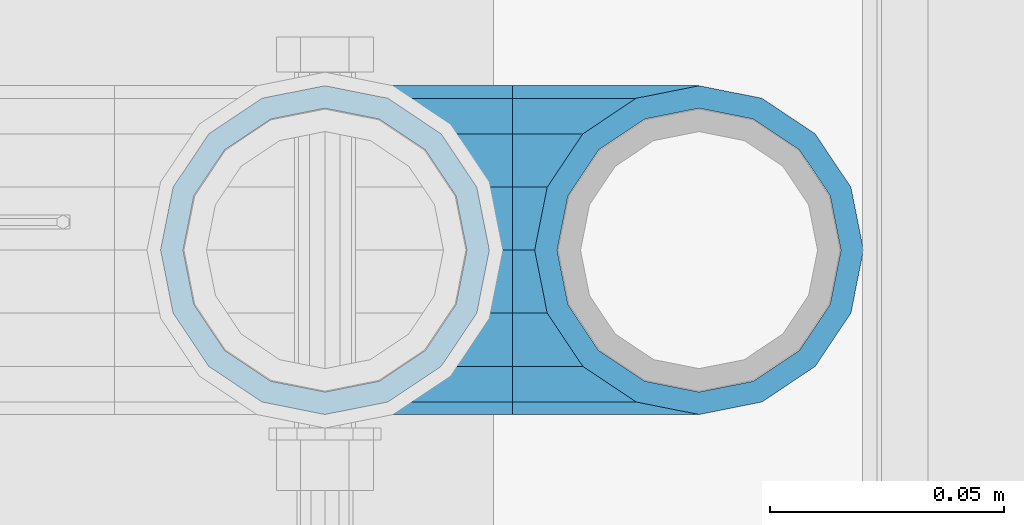
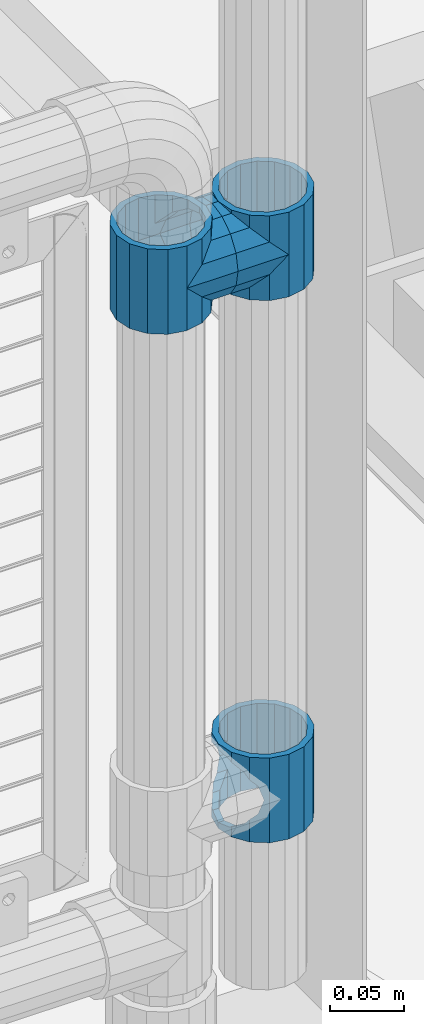
# One storey, part 172 of 247: 5 beams.
"""IFC2X3 building model written with IfcOpenShell, lengths in millimetres."""

import ifcopenshell
import ifcopenshell.guid

model = None  # the IFC model being written
_history = None  # IfcOwnerHistory: only IFC2X3 demands one
_inside = {}  # id of a spatial element -> (the spatial element, [elements in it])
_under = {}  # id of a project, library or spatial element -> (it, [spatial elements below it])
_declared = {}  # id of a project -> (the project, [libraries it declares])
_typed = {}  # id of a type object -> (the type object, [elements of that type])
_made_of = {}  # id of a material, layer set ... -> (it, [elements and type objects made of it])


def new_model(schema):
    """Start an empty IFC model of exactly this schema.

    Asked for "IFC4X3", IfcOpenShell would pick the latest addendum, in which some entities
    have other attributes; the version numbers below select the first issue.
    IFC2X3 requires an IfcOwnerHistory on every rooted entity: one is made here for all.
    """
    global model, _history
    if schema == "IFC4X3":
        model = ifcopenshell.file(schema_version=(4, 3, 0, 0))
    else:
        model = ifcopenshell.file(schema=schema)
    _inside.clear()
    _under.clear()
    _declared.clear()
    _typed.clear()
    _made_of.clear()
    _history = None
    if model.schema == "IFC2X3":
        org = make("IfcOrganization", Name="unknown")
        user = make(
            "IfcPersonAndOrganization",
            ThePerson=make("IfcPerson", FamilyName="unknown"),
            TheOrganization=org,
        )
        app = make(
            "IfcApplication",
            ApplicationDeveloper=org,
            Version="unknown",
            ApplicationFullName="unknown",
            ApplicationIdentifier="unknown",
        )
        _history = make(
            "IfcOwnerHistory",
            OwningUser=user,
            OwningApplication=app,
            ChangeAction="ADDED",
            CreationDate=0,
        )
    return model


def make(cls, **values):
    """One entity of the class cls with the attributes given. An attribute that is None is left unset."""
    return model.create_entity(
        cls, **{name: value for name, value in values.items() if value is not None}
    )


def rooted(cls, **values):
    """An entity with a GlobalId (a new one), such as an element, a storey or a relation."""
    return make(cls, GlobalId=ifcopenshell.guid.new(), OwnerHistory=_history, **values)


def si_unit(unit_type, name, prefix=None):
    """IfcSIUnit, for example si_unit("LENGTHUNIT", "METRE", prefix="MILLI")."""
    return make("IfcSIUnit", UnitType=unit_type, Prefix=prefix, Name=name)


def assignment(units):
    """IfcUnitAssignment: the units of a project."""
    return None if units is None else make("IfcUnitAssignment", Units=units)


def point(xyz):
    """IfcCartesianPoint."""
    return None if xyz is None else make("IfcCartesianPoint", Coordinates=xyz)


def direction(xyz):
    """IfcDirection."""
    return None if xyz is None else make("IfcDirection", DirectionRatios=xyz)


def frame(location, z_axis=None, x_axis=None):
    """IfcAxis2Placement3D, a coordinate frame: its origin and axes. An axis left out is left unset."""
    return make(
        "IfcAxis2Placement3D",
        Location=point(location),
        Axis=direction(z_axis),
        RefDirection=direction(x_axis),
    )


def origin_with_axes():
    """The frame at (0, 0, 0) with the z axis (0, 0, 1) and the x axis (1, 0, 0) written out."""
    return frame((0.0, 0.0, 0.0), z_axis=(0.0, 0.0, 1.0), x_axis=(1.0, 0.0, 0.0))


def place(relative_to, where):
    """IfcLocalPlacement: puts the frame where relative to a parent placement (None: the world)."""
    return make(
        "IfcLocalPlacement", PlacementRelTo=relative_to, RelativePlacement=where
    )


def context(
    kind, dimensions, precision=None, world=None, true_north=None, identifier=None
):
    """IfcGeometricRepresentationContext, for example the 3D "Model" context."""
    return make(
        "IfcGeometricRepresentationContext",
        ContextIdentifier=identifier,
        ContextType=kind,
        CoordinateSpaceDimension=dimensions,
        Precision=precision,
        WorldCoordinateSystem=world,
        TrueNorth=true_north,
    )


def subcontext(parent, identifier, kind, view, scale=None):
    """IfcGeometricRepresentationSubContext, for example "Body" below "Model"."""
    return make(
        "IfcGeometricRepresentationSubContext",
        ContextIdentifier=identifier,
        ContextType=kind,
        ParentContext=parent,
        TargetScale=scale,
        TargetView=view,
    )


def project(units=None, contexts=None):
    """IfcProject with its units and contexts."""
    return rooted(
        "IfcProject",
        Name="project",
        RepresentationContexts=contexts,
        UnitsInContext=assignment(units),
    )


def spatial(cls, under=None, at=None, **own):
    """A site, building, storey or space (cls), placed at a placement, below another one or the project."""
    s = rooted(cls, ObjectPlacement=at, **own)
    if under is not None:
        _under.setdefault(under.id(), (under, []))[1].append(s)
    return s


def faces_of(points, faces, orient=None, outer=None):
    """IfcFace entities. A face is a list of loops; a loop is a list of indices into points, from 0.

    orient and outer hold one flag for each loop. By default every Orientation is true, the
    first loop of a face is its IfcFaceOuterBound and the others are IfcFaceBound.
    """
    made = []
    for i, loops in enumerate(faces):
        bounds = []
        for j, loop in enumerate(loops):
            is_outer = j == 0 if outer is None else outer[i][j]
            bounds.append(
                make(
                    "IfcFaceOuterBound" if is_outer else "IfcFaceBound",
                    Bound=make("IfcPolyLoop", Polygon=[points[k] for k in loop]),
                    Orientation=True if orient is None else orient[i][j],
                )
            )
        made.append(make("IfcFace", Bounds=bounds))
    return made


def faceted_brep(points, faces, orient=None, outer=None, voids=None):
    """IfcFacetedBrep: a solid bounded by flat faces; with voids (closed shells), ...WithVoids."""
    shared = [point(p) for p in points]
    hull = make("IfcClosedShell", CfsFaces=faces_of(shared, faces, orient, outer))
    if voids is None:
        return make("IfcFacetedBrep", Outer=hull)
    return make(
        "IfcFacetedBrepWithVoids",
        Outer=hull,
        Voids=[
            make(cls, CfsFaces=faces_of(shared, fs, o, b)) for cls, fs, o, b in voids
        ],
    )


def shape(context_of_items, identifier, shape_type, items):
    """IfcShapeRepresentation: the items that make up one representation, for example the "Body"."""
    return make(
        "IfcShapeRepresentation",
        ContextOfItems=context_of_items,
        RepresentationIdentifier=identifier,
        RepresentationType=shape_type,
        Items=items,
    )


def material(Name=None, Category=None):
    """IfcMaterial."""
    return make("IfcMaterial", Name=Name, Category=Category)


def made_of(thing, what):
    """Note that an element or type object is made of a material, layer set ...; save() writes the relation."""
    if what is not None:
        _made_of.setdefault(what.id(), (what, []))[1].append(thing)
    return thing


def type_object(cls, material=None, **own):
    """A type object (cls), such as IfcWallType, which elements share."""
    return made_of(rooted(cls, **own), material)


def element(
    cls,
    number,
    at=None,
    inside=None,
    cuts=None,
    type_object=None,
    material=None,
    context=None,
    identifier="Body",
    shape_type=None,
    held_by="IfcProductDefinitionShape",
    body=None,
    shapes=None,
    **own,
):
    """One element of the class cls, such as IfcWall. Its Tag is "e" and its number.

    at: its placement. inside: the storey or other place that contains it. cuts: it is an
    opening in that element (IfcRelVoidsElement). A single representation is given by context,
    identifier, shape_type and body (its items); several are given by shapes. held_by: the class
    of the entity that holds the representations. save() writes the other relations.
    """
    e = rooted(cls, Tag="e%d" % number, ObjectPlacement=at, **own)
    if body is not None:
        shapes = [shape(context, identifier, shape_type, body)]
    if shapes is not None:
        e.Representation = make(held_by, Representations=shapes)
    if inside is not None:
        _inside.setdefault(inside.id(), (inside, []))[1].append(e)
    if cuts is not None:
        rooted(
            "IfcRelVoidsElement", RelatingBuildingElement=cuts, RelatedOpeningElement=e
        )
    if type_object is not None:
        _typed.setdefault(type_object.id(), (type_object, []))[1].append(e)
    return made_of(e, material)


def aggregate(whole, parts):
    """IfcRelAggregates: a whole, such as a stair, and the parts it consists of."""
    return rooted("IfcRelAggregates", RelatingObject=whole, RelatedObjects=parts)


def save(model, path):
    """Write the relations noted so far, then the file.

    IfcRelAggregates (storeys below a building ...), IfcRelContainedInSpatialStructure (elements
    in a storey), IfcRelDefinesByType, IfcRelAssociatesMaterial and IfcRelDeclares: one each for
    every whole, place, type object, material and project.
    """
    for whole, parts in _under.values():
        aggregate(whole, parts)
    for where, things in _inside.values():
        rooted(
            "IfcRelContainedInSpatialStructure",
            RelatedElements=things,
            RelatingStructure=where,
        )
    for kind, things in _typed.values():
        rooted("IfcRelDefinesByType", RelatedObjects=things, RelatingType=kind)
    for what, things in _made_of.values():
        rooted("IfcRelAssociatesMaterial", RelatedObjects=things, RelatingMaterial=what)
    for by, libraries in _declared.values():
        rooted("IfcRelDeclares", RelatingContext=by, RelatedDefinitions=libraries)
    model.write(path)


model = new_model("IFC2X3")

# Units and contexts
model_context = context("Model", 3, precision=1e-05, world=origin_with_axes())
body_context = subcontext(model_context, "Body", "Model", "MODEL_VIEW")
ifc_project = project(units=[si_unit("LENGTHUNIT", "METRE", prefix="MILLI"), si_unit("AREAUNIT", "SQUARE_METRE"), si_unit("VOLUMEUNIT", "CUBIC_METRE"), si_unit("MASSUNIT", "GRAM", prefix="KILO"), si_unit("TIMEUNIT", "SECOND"), si_unit("PLANEANGLEUNIT", "RADIAN"), si_unit("SOLIDANGLEUNIT", "STERADIAN"), si_unit("THERMODYNAMICTEMPERATUREUNIT", "DEGREE_CELSIUS"), si_unit("LUMINOUSINTENSITYUNIT", "LUMEN")], contexts=[model_context])

# Site, building, storey
site_placement = place(None, origin_with_axes())
site = spatial("IfcSite", under=ifc_project, at=site_placement, CompositionType="ELEMENT")
building_placement = place(site_placement, origin_with_axes())
building = spatial("IfcBuilding", under=site, at=building_placement, Name="Standard", CompositionType="ELEMENT")
storey_placement = place(building_placement, origin_with_axes())
storey = spatial("IfcBuildingStorey", under=building, at=storey_placement, Name="Undefined", CompositionType="ELEMENT", Elevation=0.0)

# Beams
ifc_material = material(Name="Misc_Undefined")
beam_type = type_object("IfcBeamType", PredefinedType="NOTDEFINED")
beam_1_placement = place(storey_placement, frame((16301.0, 7664.5, 433.819999999999), z_axis=(1.0, 0.0, 0.0), x_axis=(0.0, 0.0, -1.0)))
element("IfcBeam", 1, at=beam_1_placement, inside=storey, type_object=beam_type, material=ifc_material, context=body_context, shape_type="Brep", body=[
    faceted_brep([(46.7644421722801, 28.0397438117179, -11.6144421722802), (46.7644421722801, 28.0397438117179, -20.088203122983), (51.5310424080055, 24.8548033587067, -24.8548033587067), (56.6106908090114, 21.4606908090118, -27.1226768591096), (56.6106908090114, 21.4606908090118, -21.4606908090118), (61.9623795176755, 13.4513226476329, -32.4743655677721), (63.1897438117172, 11.6144421722802, -32.839743811719), (63.1897438117172, 11.6144421722802, -28.0397438117179), (65.4999999999997, 0.0, -35.1499999999996), (65.4999999999997, 0.0, -30.3500000000004), (63.1897438117172, -11.6144421722802, -32.839743811719), (63.1897438117172, -11.6144421722802, -28.0397438117179), (61.9623795176754, -13.4513226476329, -32.4743655677721), (56.6106908090114, -21.4606908090118, -27.1226768591077), (56.6106908090114, -21.4606908090118, -21.4606908090118), (51.5310424080038, -24.8548033587067, -24.8548033587067), (46.7644421722801, -28.0397438117179, -20.0882031229885), (46.7644421722801, -28.0397438117179, -11.6144421722802), (35.1499999999996, -30.3500000000004, -16.6306603983739), (35.1499999999996, -30.35, 0.0), (23.5355578277191, -28.0397438117179, -20.0882031229885), (23.5355578277191, -28.0397438117179, -11.6144421722802), (18.768957591997, -24.8548033587067, -24.8548033587067), (13.6893091909879, -21.4606908090118, -27.1226768591077), (13.6893091909879, -21.4606908090118, -21.4606908090118), (8.33762048232325, -13.4513226476329, -32.4743655677721), (7.11025618828211, -11.6144421722802, -32.839743811719), (7.11025618828211, -11.6144421722802, -28.0397438117179), (4.79999999999961, 0.0, -35.1499999999996), (4.79999999999961, 0.0, -30.3500000000004), (7.11025618828211, 11.6144421722802, -32.839743811719), (7.11025618828211, 11.6144421722802, -28.0397438117179), (8.33762048232387, 13.4513226476329, -32.4743655677721), (13.6893091909879, 21.4606908090118, -27.1226768591096), (13.6893091909879, 21.4606908090118, -21.4606908090118), (18.768957591997, 24.8548033587067, -24.8548033587067), (23.5355578277192, 28.0397438117179, -20.088203122983), (23.5355578277192, 28.0397438117179, -11.6144421722802), (35.1499999999996, 30.3500000000004, -16.6306603983649), (35.1499999999996, 30.35, 0.0), (0.0, 32.4743655677721, -13.4513226476338), (0.0, 35.1499999999996, 0.0), (70.2999999999993, 35.1499999999996, 0.0), (70.2999999999993, 32.4743655677721, -13.4513226476338), (0.0, 32.4743655677721, 13.4513226476338), (70.2999999999993, 32.4743655677721, 13.4513226476338), (0.0, 24.8548033587067, 24.8548033587067), (70.2999999999993, 24.8548033587067, 24.8548033587067), (0.0, 13.4513226476329, 32.4743655677721), (70.2999999999993, 13.4513226476329, 32.4743655677721), (0.0, 0.0, 35.1499999999996), (70.2999999999993, 0.0, 35.1499999999996), (0.0, -13.4513226476329, 32.4743655677721), (70.2999999999993, -13.4513226476329, 32.4743655677721), (0.0, -24.8548033587067, 24.8548033587067), (70.2999999999993, -24.8548033587067, 24.8548033587067), (0.0, -32.4743655677721, 13.4513226476338), (70.2999999999993, -32.4743655677721, 13.4513226476338), (0.0, -35.1499999999996, 0.0), (70.2999999999993, -35.1499999999996, 0.0), (70.2999999999993, -30.3500000000004, 0.0), (70.2999999999993, -28.0397438117179, -11.6144421722802), (70.2999999999993, -21.4606908090118, -21.4606908090118), (70.2999999999993, -11.6144421722802, -28.0397438117179), (70.2999999999993, 0.0, -30.3500000000004), (70.2999999999993, 11.6144421722802, -28.0397438117179), (70.2999999999993, 21.4606908090118, -21.4606908090118), (70.2999999999993, 28.0397438117179, -11.6144421722802), (0.0, -28.0397438117179, -11.6144421722802), (0.0, -30.3500000000004, 0.0), (0.0, -21.4606908090118, -21.4606908090118), (0.0, -11.6144421722802, -28.0397438117179), (0.0, 0.0, -30.3500000000004), (0.0, 11.6144421722802, -28.0397438117179), (0.0, 21.4606908090118, -21.4606908090118), (0.0, 28.0397438117179, -11.6144421722802), (0.0, 30.3500000000004, 0.0), (70.2999999999993, 30.3500000000004, 0.0), (0.0, 28.0397438117179, 11.6144421722802), (70.2999999999993, 28.0397438117179, 11.6144421722802), (0.0, 21.4606908090118, 21.4606908090118), (70.2999999999993, 21.4606908090118, 21.4606908090118), (0.0, 11.6144421722802, 28.0397438117179), (70.2999999999993, 11.6144421722802, 28.0397438117179), (0.0, 0.0, 30.3500000000004), (70.2999999999993, 0.0, 30.3500000000004), (0.0, -11.6144421722802, 28.0397438117179), (70.2999999999993, -11.6144421722802, 28.0397438117179), (0.0, -21.4606908090118, 21.4606908090118), (70.2999999999993, -21.4606908090118, 21.4606908090118), (0.0, -28.0397438117179, 11.6144421722802), (70.2999999999993, -28.0397438117179, 11.6144421722802), (70.2999999999993, -24.8548033587067, -24.8548033587067), (70.2999999999993, -13.4513226476329, -32.4743655677721), (70.2999999999993, 0.0, -35.1499999999996), (70.2999999999993, 13.4513226476329, -32.4743655677721), (70.2999999999993, 24.8548033587067, -24.8548033587067), (70.2999999999993, -32.4743655677721, -13.4513226476338), (0.0, -32.4743655677721, -13.4513226476338), (0.0, 24.8548033587067, -24.8548033587067), (0.0, 13.4513226476329, -32.4743655677721), (0.0, 0.0, -35.1499999999996), (0.0, -13.4513226476329, -32.4743655677721), (0.0, -24.8548033587067, -24.8548033587067)], [[[0, 1, 2, 3, 4]], [[4, 3, 5, 6, 7]], [[7, 6, 8, 9]], [[9, 8, 10, 11]], [[11, 10, 12, 13, 14]], [[14, 13, 15, 16, 17]], [[17, 16, 18, 19]], [[19, 18, 20, 21]], [[21, 20, 22, 23, 24]], [[24, 23, 25, 26, 27]], [[27, 26, 28, 29]], [[29, 28, 30, 31]], [[31, 30, 32, 33, 34]], [[34, 33, 35, 36, 37]], [[37, 36, 38, 39]], [[39, 38, 1, 0]], [[40, 41, 42, 43]], [[41, 44, 45, 42]], [[44, 46, 47, 45]], [[46, 48, 49, 47]], [[48, 50, 51, 49]], [[50, 52, 53, 51]], [[52, 54, 55, 53]], [[54, 56, 57, 55]], [[56, 58, 59, 57]], [[60, 61, 17, 19]], [[61, 62, 14, 17]], [[62, 63, 11, 14]], [[63, 64, 9, 11]], [[64, 65, 7, 9]], [[65, 66, 4, 7]], [[66, 67, 0, 4]], [[68, 69, 19, 21]], [[70, 68, 21, 24]], [[71, 70, 24, 27]], [[72, 71, 27, 29]], [[73, 72, 29, 31]], [[74, 73, 31, 34]], [[75, 74, 34, 37]], [[76, 75, 37, 39]], [[67, 77, 39, 0]], [[78, 76, 39, 77, 79]], [[80, 78, 79, 81]], [[82, 80, 81, 83]], [[84, 82, 83, 85]], [[86, 84, 85, 87]], [[88, 86, 87, 89]], [[90, 88, 89, 91]], [[19, 69, 90, 91, 60]], [[92, 93, 94, 95, 96, 43, 42, 45, 47, 49, 51, 53, 55, 57, 59, 97], [89, 87, 85, 83, 81, 79, 77, 67, 66, 65, 64, 63, 62, 61, 60, 91]], [[58, 98, 97, 59]], [[56, 54, 52, 50, 48, 46, 44, 41, 40, 99, 100, 101, 102, 103, 98, 58], [68, 70, 71, 72, 73, 74, 75, 76, 78, 80, 82, 84, 86, 88, 90, 69]], [[32, 100, 99, 35, 33]], [[28, 101, 100, 32, 30]], [[102, 101, 28, 26, 25]], [[103, 102, 25, 23, 22]], [[15, 92, 97, 98, 103, 22, 20, 18, 16]], [[12, 93, 92, 15, 13]], [[8, 94, 93, 12, 10]], [[95, 94, 8, 6, 5]], [[96, 95, 5, 3, 2]], [[35, 99, 40, 43, 96, 2, 1, 38, 36]]]),
])
beam_2_placement = place(storey_placement, frame((16221.0, 7664.5, 848.67), z_axis=(0.0, -0.999999999999548, -9.5100000000016e-07), x_axis=(1.0, 0.0, 0.0)))
element("IfcBeam", 2, at=beam_2_placement, inside=storey, type_object=beam_type, material=ifc_material, context=body_context, shape_type="Brep", body=[
    faceted_brep([(0.0, 0.0, -35.1499999999996), (13.4513226476338, -13.4513226476329, -32.4743655677721), (13.4513226476338, 13.4513226476329, -32.4743655677721), (32.4743655677721, 32.4743655677717, 13.4513226476329), (32.4743655677721, 26.8123795176755, 13.4513226476329), (27.1226768591096, 21.4606908090117, 21.4606908090118), (24.8548033587067, 16.3810424080046, 24.8548033587067), (24.8548033587067, 24.8548033587072, 24.8548033587067), (0.0, 0.0, 35.1499999999996), (13.4513226476338, 13.4513226476329, 32.4743655677721), (13.4513226476338, -13.4513226476329, 32.4743655677721), (20.0882031229812, 11.6144421722805, 28.0397438117179), (16.6306603983649, 0.0, 30.3500000000004), (20.0882031229812, -11.6144421722805, 28.0397438117179), (24.8548033587067, -16.3810424080045, 24.8548033587067), (24.8548033587067, -24.8548033587072, 24.8548033587067), (27.1226768591096, -21.4606908090117, 21.4606908090118), (32.4743655677721, -26.8123795176755, 13.4513226476329), (32.4743655677721, -32.4743655677717, 13.4513226476329), (32.8397438117172, -28.0397438117175, 11.6144421722802), (35.1499999999996, -30.35, 0.0), (35.1499999999996, -35.15, 0.0), (32.4743655677721, -26.8123795176766, -13.4513226476329), (32.4743655677721, -32.4743655677717, -13.4513226476329), (32.8397438117172, -28.0397438117175, -11.6144421722802), (24.8548033587067, -16.3810424080045, -24.8548033587067), (24.8548033587067, -24.8548033587072, -24.8548033587067), (27.1226768591059, -21.4606908090117, -21.4606908090118), (20.0882031229885, -11.6144421722805, -28.0397438117179), (16.6306603983739, 0.0, -30.3500000000004), (20.0882031229885, 11.6144421722805, -28.0397438117179), (24.8548033587067, 16.3810424080029, -24.8548033587067), (24.8548033587067, 24.8548033587072, -24.8548033587067), (27.1226768591059, 21.4606908090117, -21.4606908090118), (32.4743655677721, 26.8123795176755, -13.4513226476329), (32.4743655677721, 32.4743655677717, -13.4513226476329), (32.8397438117172, 28.0397438117175, -11.6144421722802), (35.1499999999996, 30.35, 0.0), (35.1499999999996, 35.15, 0.0), (32.8397438117172, 28.0397438117175, 11.6144421722802), (40.1500000000015, -35.15, 0.0), (40.1500000000015, -32.4743655677717, 13.4513226476329), (40.1500000000015, -24.8548033587072, 24.8548033587067), (40.1500000000015, -13.4513226476329, 32.4743655677721), (40.1500000000015, 0.0, 35.1499999999996), (40.1500000000015, 13.4513226476329, 32.4743655677721), (40.1500000000015, 24.8548033587072, 24.8548033587067), (40.1500000000015, 32.4743655677717, 13.4513226476329), (40.1500000000015, 35.15, 0.0), (40.1500000000015, -24.8548033587072, -24.8548033587067), (40.1500000000015, -32.4743655677717, -13.4513226476329), (40.1500000000015, -13.4513226476329, -32.4743655677721), (40.1500000000015, 0.0, -35.1499999999996), (40.1500000000015, 13.4513226476329, -32.4743655677721), (40.1500000000015, 24.8548033587072, -24.8548033587067), (40.1500000000015, 32.4743655677717, -13.4513226476329), (40.1500000000015, -21.4606908090117, 21.4606908090118), (40.1500000000015, -11.6144421722805, 28.0397438117179), (40.1500000000015, 0.0, 30.3500000000004), (40.1500000000015, 11.6144421722805, 28.0397438117179), (40.1500000000015, 21.4606908090117, 21.4606908090118), (40.1500000000015, 28.0397438117175, 11.6144421722802), (40.1500000000015, 30.35, 0.0), (40.1500000000015, 28.0397438117175, -11.6144421722802), (40.1500000000015, 21.4606908090117, -21.4606908090118), (40.1500000000015, 11.6144421722805, -28.0397438117179), (40.1500000000015, 0.0, -30.3500000000004), (40.1500000000015, -11.6144421722805, -28.0397438117179), (40.1500000000015, -21.4606908090117, -21.4606908090118), (40.1500000000015, -28.0397438117175, -11.6144421722802), (40.1500000000015, -30.35, 0.0), (40.1500000000015, -28.0397438117175, 11.6144421722802)], [[[0, 1, 2]], [[3, 4, 5, 6, 7]], [[8, 9, 10]], [[7, 6, 11, 12, 13, 14, 15, 10, 9]], [[16, 17, 18, 15, 14]], [[19, 20, 21, 18, 17]], [[22, 23, 21, 20, 24]], [[25, 26, 23, 22, 27]], [[2, 1, 26, 25, 28, 29, 30, 31, 32]], [[32, 31, 33, 34, 35]], [[35, 34, 36, 37, 38]], [[38, 37, 39, 4, 3]], [[40, 41, 18, 21]], [[41, 42, 15, 18]], [[42, 43, 10, 15]], [[43, 44, 8, 10]], [[44, 45, 9, 8]], [[45, 46, 7, 9]], [[46, 47, 3, 7]], [[47, 48, 38, 3]], [[49, 50, 23, 26]], [[51, 49, 26, 1]], [[52, 51, 1, 0]], [[53, 52, 0, 2]], [[54, 53, 2, 32]], [[55, 54, 32, 35]], [[48, 55, 35, 38]], [[50, 40, 21, 23]], [[49, 51, 52, 53, 54, 55, 48, 47, 46, 45, 44, 43, 42, 41, 40, 50], [56, 57, 58, 59, 60, 61, 62, 63, 64, 65, 66, 67, 68, 69, 70, 71]], [[63, 62, 37, 36]], [[33, 64, 63, 36, 34]], [[30, 65, 64, 33, 31]], [[66, 65, 30, 29]], [[67, 66, 29, 28]], [[68, 67, 28, 25, 27]], [[69, 68, 27, 22, 24]], [[70, 69, 24, 20]], [[71, 70, 20, 19]], [[16, 56, 71, 19, 17]], [[13, 57, 56, 16, 14]], [[58, 57, 13, 12]], [[59, 58, 12, 11]], [[60, 59, 11, 6, 5]], [[61, 60, 5, 4, 39]], [[62, 61, 39, 37]]]),
])
beam_3_placement = place(storey_placement, frame((16301.0, 7664.5, 848.67), z_axis=(0.0, 1.0, 0.0), x_axis=(-1.0, 0.0, 0.0)))
element("IfcBeam", 3, at=beam_3_placement, inside=storey, type_object=beam_type, material=ifc_material, context=body_context, shape_type="Brep", body=[
    faceted_brep([(0.0, 0.0, -35.1499999999996), (13.4513226476338, -13.4513226476329, -32.4743655677721), (13.4513226476338, 13.4513226476329, -32.4743655677721), (27.1226768591096, -21.4606908090117, 21.4606908090118), (32.4743655677721, -26.8123795176755, 13.4513226476329), (32.4743655677721, -32.4743655677717, 13.4513226476329), (24.8548033587067, -24.8548033587072, 24.8548033587067), (24.8548033587067, -16.3810424080045, 24.8548033587067), (32.8397438117172, -28.0397438117175, 11.6144421722802), (35.1499999999996, -30.35, 0.0), (35.1499999999996, -35.15, 0.0), (32.4743655677721, -26.8123795176766, -13.4513226476329), (32.4743655677721, -32.4743655677717, -13.4513226476329), (32.8397438117172, -28.0397438117175, -11.6144421722802), (24.8548033587067, -16.3810424080045, -24.8548033587067), (24.8548033587067, -24.8548033587072, -24.8548033587067), (27.1226768591059, -21.4606908090117, -21.4606908090118), (20.0882031229885, -11.6144421722805, -28.0397438117179), (16.6306603983739, 0.0, -30.3500000000004), (20.0882031229885, 11.6144421722805, -28.0397438117179), (24.8548033587067, 16.3810424080029, -24.8548033587067), (24.8548033587067, 24.8548033587072, -24.8548033587067), (27.1226768591059, 21.4606908090117, -21.4606908090118), (32.4743655677721, 26.8123795176755, -13.4513226476329), (32.4743655677721, 32.4743655677717, -13.4513226476329), (32.8397438117172, 28.0397438117175, -11.6144421722802), (35.1499999999996, 30.35, 0.0), (35.1499999999996, 35.15, 0.0), (32.8397438117172, 28.0397438117175, 11.6144421722802), (32.4743655677721, 26.8123795176755, 13.4513226476329), (32.4743655677721, 32.4743655677717, 13.4513226476329), (27.1226768591096, 21.4606908090117, 21.4606908090118), (24.8548033587067, 16.3810424080046, 24.8548033587067), (24.8548033587067, 24.8548033587072, 24.8548033587067), (0.0, 0.0, 35.1499999999996), (13.4513226476338, 13.4513226476329, 32.4743655677721), (13.4513226476338, -13.4513226476329, 32.4743655677721), (20.0882031229812, 11.6144421722805, 28.0397438117179), (16.6306603983649, 0.0, 30.3500000000004), (20.0882031229812, -11.6144421722805, 28.0397438117179), (40.1500000000015, -35.15, 0.0), (40.1500000000015, -32.4743655677717, 13.4513226476329), (40.1500000000015, -24.8548033587072, 24.8548033587067), (40.1500000000015, -13.4513226476329, 32.4743655677721), (40.1500000000015, 0.0, 35.1499999999996), (40.1500000000015, -24.8548033587072, -24.8548033587067), (40.1500000000015, -32.4743655677717, -13.4513226476329), (40.1500000000015, -13.4513226476329, -32.4743655677721), (40.1500000000015, 0.0, -35.1499999999996), (40.1500000000015, 13.4513226476329, -32.4743655677721), (40.1500000000015, 24.8548033587072, -24.8548033587067), (40.1500000000015, 32.4743655677717, -13.4513226476329), (40.1500000000015, 35.15, 0.0), (40.1500000000015, 32.4743655677717, 13.4513226476329), (40.1500000000015, 24.8548033587072, 24.8548033587067), (40.1500000000015, 13.4513226476329, 32.4743655677721), (40.1500000000015, -21.4606908090117, 21.4606908090118), (40.1500000000015, -11.6144421722805, 28.0397438117179), (40.1500000000015, 0.0, 30.3500000000004), (40.1500000000015, 11.6144421722805, 28.0397438117179), (40.1500000000015, 21.4606908090117, 21.4606908090118), (40.1500000000015, 28.0397438117175, 11.6144421722802), (40.1500000000015, 30.35, 0.0), (40.1500000000015, 28.0397438117175, -11.6144421722802), (40.1500000000015, 21.4606908090117, -21.4606908090118), (40.1500000000015, 11.6144421722805, -28.0397438117179), (40.1500000000015, 0.0, -30.3500000000004), (40.1500000000015, -11.6144421722805, -28.0397438117179), (40.1500000000015, -21.4606908090117, -21.4606908090118), (40.1500000000015, -28.0397438117175, -11.6144421722802), (40.1500000000015, -30.35, 0.0), (40.1500000000015, -28.0397438117175, 11.6144421722802)], [[[0, 1, 2]], [[3, 4, 5, 6, 7]], [[8, 9, 10, 5, 4]], [[11, 12, 10, 9, 13]], [[14, 15, 12, 11, 16]], [[2, 1, 15, 14, 17, 18, 19, 20, 21]], [[21, 20, 22, 23, 24]], [[24, 23, 25, 26, 27]], [[27, 26, 28, 29, 30]], [[30, 29, 31, 32, 33]], [[34, 35, 36]], [[33, 32, 37, 38, 39, 7, 6, 36, 35]], [[40, 41, 5, 10]], [[41, 42, 6, 5]], [[42, 43, 36, 6]], [[43, 44, 34, 36]], [[45, 46, 12, 15]], [[47, 45, 15, 1]], [[48, 47, 1, 0]], [[49, 48, 0, 2]], [[50, 49, 2, 21]], [[51, 50, 21, 24]], [[52, 51, 24, 27]], [[53, 52, 27, 30]], [[54, 53, 30, 33]], [[55, 54, 33, 35]], [[44, 55, 35, 34]], [[46, 40, 10, 12]], [[45, 47, 48, 49, 50, 51, 52, 53, 54, 55, 44, 43, 42, 41, 40, 46], [56, 57, 58, 59, 60, 61, 62, 63, 64, 65, 66, 67, 68, 69, 70, 71]], [[59, 58, 38, 37]], [[60, 59, 37, 32, 31]], [[61, 60, 31, 29, 28]], [[62, 61, 28, 26]], [[63, 62, 26, 25]], [[22, 64, 63, 25, 23]], [[19, 65, 64, 22, 20]], [[66, 65, 19, 18]], [[67, 66, 18, 17]], [[68, 67, 17, 14, 16]], [[69, 68, 16, 11, 13]], [[70, 69, 13, 9]], [[71, 70, 9, 8]], [[3, 56, 71, 8, 4]], [[39, 57, 56, 3, 7]], [[58, 57, 39, 38]]]),
])
beam_4_placement = place(storey_placement, frame((16221.0, 7664.5, 883.819999999999), z_axis=(-1.0, 0.0, 0.0), x_axis=(0.0, 0.0, -1.0)))
element("IfcBeam", 4, at=beam_4_placement, inside=storey, type_object=beam_type, material=ifc_material, context=body_context, shape_type="Brep", body=[
    faceted_brep([(13.6893091909879, -21.4606908090118, -21.4606908090118), (13.6893091909879, -21.4606908090118, -27.1226768591077), (8.33762048232325, -13.4513226476329, -32.4743655677721), (7.11025618828211, -11.6144421722802, -32.839743811719), (7.11025618828211, -11.6144421722802, -28.0397438117179), (23.5355578277191, -28.0397438117179, -11.6144421722802), (23.5355578277191, -28.0397438117179, -20.0882031229885), (18.768957591997, -24.8548033587067, -24.8548033587067), (35.1499999999996, -30.35, 0.0), (35.1499999999996, -30.3500000000004, -16.6306603983739), (46.7644421722801, -28.0397438117179, -11.6144421722802), (46.7644421722801, -28.0397438117179, -20.0882031229885), (56.6106908090114, -21.4606908090118, -21.4606908090118), (56.6106908090114, -21.4606908090118, -27.1226768591077), (51.5310424080038, -24.8548033587067, -24.8548033587067), (63.1897438117172, -11.6144421722802, -28.0397438117179), (63.1897438117172, -11.6144421722802, -32.839743811719), (61.9623795176754, -13.4513226476329, -32.4743655677721), (65.4999999999997, 0.0, -30.3500000000004), (65.4999999999997, 0.0, -35.1499999999996), (63.1897438117172, 11.6144421722802, -28.0397438117179), (63.1897438117172, 11.6144421722802, -32.839743811719), (56.6106908090114, 21.4606908090118, -21.4606908090118), (56.6106908090114, 21.4606908090118, -27.1226768591096), (61.9623795176755, 13.4513226476329, -32.4743655677721), (46.7644421722801, 28.0397438117179, -11.6144421722802), (46.7644421722801, 28.0397438117179, -20.088203122983), (51.5310424080055, 24.8548033587067, -24.8548033587067), (35.1499999999996, 30.35, 0.0), (35.1499999999996, 30.3500000000004, -16.6306603983649), (23.5355578277192, 28.0397438117179, -11.6144421722802), (23.5355578277192, 28.0397438117179, -20.088203122983), (13.6893091909879, 21.4606908090118, -21.4606908090118), (13.6893091909879, 21.4606908090118, -27.1226768591096), (18.768957591997, 24.8548033587067, -24.8548033587067), (7.11025618828211, 11.6144421722802, -28.0397438117179), (7.11025618828211, 11.6144421722802, -32.839743811719), (8.33762048232387, 13.4513226476329, -32.4743655677721), (4.79999999999961, 0.0, -30.3500000000004), (4.79999999999961, 0.0, -35.1499999999996), (0.0, 21.4606908090118, 21.4606908090118), (0.0, 28.0397438117179, 11.6144421722802), (70.2999999999993, 28.0397438117179, 11.6144421722802), (70.2999999999993, 21.4606908090118, 21.4606908090118), (0.0, 11.6144421722802, 28.0397438117179), (70.2999999999993, 11.6144421722802, 28.0397438117179), (0.0, 0.0, 30.3500000000004), (70.2999999999993, 0.0, 30.3500000000004), (0.0, -11.6144421722802, 28.0397438117179), (70.2999999999993, -11.6144421722802, 28.0397438117179), (0.0, -21.4606908090118, 21.4606908090118), (70.2999999999993, -21.4606908090118, 21.4606908090118), (0.0, -28.0397438117179, 11.6144421722802), (70.2999999999993, -28.0397438117179, 11.6144421722802), (0.0, -24.8548033587067, -24.8548033587067), (0.0, -13.4513226476329, -32.4743655677721), (0.0, 0.0, -35.1499999999996), (0.0, -32.4743655677721, 13.4513226476338), (0.0, -35.1499999999996, 0.0), (70.2999999999993, -35.1499999999996, 0.0), (70.2999999999993, -32.4743655677721, 13.4513226476338), (0.0, -24.8548033587067, 24.8548033587067), (70.2999999999993, -24.8548033587067, 24.8548033587067), (0.0, -13.4513226476329, 32.4743655677721), (70.2999999999993, -13.4513226476329, 32.4743655677721), (0.0, 0.0, 35.1499999999996), (70.2999999999993, 0.0, 35.1499999999996), (0.0, 13.4513226476329, 32.4743655677721), (70.2999999999993, 13.4513226476329, 32.4743655677721), (0.0, 24.8548033587067, 24.8548033587067), (70.2999999999993, 24.8548033587067, 24.8548033587067), (0.0, 32.4743655677721, 13.4513226476338), (70.2999999999993, 32.4743655677721, 13.4513226476338), (0.0, 35.1499999999996, 0.0), (70.2999999999993, 35.1499999999996, 0.0), (0.0, 32.4743655677721, -13.4513226476338), (70.2999999999993, 32.4743655677721, -13.4513226476338), (70.2999999999993, -13.4513226476329, -32.4743655677721), (70.2999999999993, -24.8548033587067, -24.8548033587067), (70.2999999999993, 0.0, -35.1499999999996), (70.2999999999993, 13.4513226476329, -32.4743655677721), (70.2999999999993, 24.8548033587067, -24.8548033587067), (0.0, 24.8548033587067, -24.8548033587067), (0.0, 13.4513226476329, -32.4743655677721), (70.2999999999993, -32.4743655677721, -13.4513226476338), (0.0, -32.4743655677721, -13.4513226476338), (0.0, -28.0397438117179, -11.6144421722802), (0.0, -21.4606908090118, -21.4606908090118), (0.0, -11.6144421722802, -28.0397438117179), (0.0, 0.0, -30.3500000000004), (0.0, 11.6144421722802, -28.0397438117179), (0.0, 21.4606908090118, -21.4606908090118), (0.0, 28.0397438117179, -11.6144421722802), (0.0, 30.3500000000004, 0.0), (0.0, -30.3500000000004, 0.0), (70.2999999999993, 30.3500000000004, 0.0), (70.2999999999993, 28.0397438117179, -11.6144421722802), (70.2999999999993, 21.4606908090118, -21.4606908090118), (70.2999999999993, 11.6144421722802, -28.0397438117179), (70.2999999999993, 0.0, -30.3500000000004), (70.2999999999993, -11.6144421722802, -28.0397438117179), (70.2999999999993, -21.4606908090118, -21.4606908090118), (70.2999999999993, -28.0397438117179, -11.6144421722802), (70.2999999999993, -30.3500000000004, 0.0)], [[[0, 1, 2, 3, 4]], [[5, 6, 7, 1, 0]], [[8, 9, 6, 5]], [[10, 11, 9, 8]], [[12, 13, 14, 11, 10]], [[15, 16, 17, 13, 12]], [[18, 19, 16, 15]], [[20, 21, 19, 18]], [[22, 23, 24, 21, 20]], [[25, 26, 27, 23, 22]], [[28, 29, 26, 25]], [[30, 31, 29, 28]], [[32, 33, 34, 31, 30]], [[35, 36, 37, 33, 32]], [[38, 39, 36, 35]], [[4, 3, 39, 38]], [[40, 41, 42, 43]], [[44, 40, 43, 45]], [[46, 44, 45, 47]], [[48, 46, 47, 49]], [[50, 48, 49, 51]], [[52, 50, 51, 53]], [[54, 55, 2, 1, 7]], [[55, 56, 39, 3, 2]], [[57, 58, 59, 60]], [[61, 57, 60, 62]], [[63, 61, 62, 64]], [[65, 63, 64, 66]], [[67, 65, 66, 68]], [[69, 67, 68, 70]], [[71, 69, 70, 72]], [[73, 71, 72, 74]], [[75, 73, 74, 76]], [[17, 77, 78, 14, 13]], [[19, 79, 77, 17, 16]], [[80, 79, 19, 21, 24]], [[81, 80, 24, 23, 27]], [[34, 82, 75, 76, 81, 27, 26, 29, 31]], [[37, 83, 82, 34, 33]], [[39, 56, 83, 37, 36]], [[14, 78, 84, 85, 54, 7, 6, 9, 11]], [[58, 85, 84, 59]], [[57, 61, 63, 65, 67, 69, 71, 73, 75, 82, 83, 56, 55, 54, 85, 58], [86, 87, 88, 89, 90, 91, 92, 93, 41, 40, 44, 46, 48, 50, 52, 94]], [[90, 89, 38, 35]], [[91, 90, 35, 32]], [[92, 91, 32, 30]], [[93, 92, 30, 28]], [[41, 93, 28, 95, 42]], [[96, 95, 28, 25]], [[97, 96, 25, 22]], [[98, 97, 22, 20]], [[99, 98, 20, 18]], [[100, 99, 18, 15]], [[101, 100, 15, 12]], [[102, 101, 12, 10]], [[103, 102, 10, 8]], [[78, 77, 79, 80, 81, 76, 74, 72, 70, 68, 66, 64, 62, 60, 59, 84], [51, 49, 47, 45, 43, 42, 95, 96, 97, 98, 99, 100, 101, 102, 103, 53]], [[8, 94, 52, 53, 103]], [[86, 94, 8, 5]], [[87, 86, 5, 0]], [[88, 87, 0, 4]], [[89, 88, 4, 38]]]),
])
beam_5_placement = place(storey_placement, frame((16301.0, 7664.5, 883.819999999999), z_axis=(1.0, 0.0, 0.0), x_axis=(0.0, 0.0, -1.0)))
element("IfcBeam", 5, at=beam_5_placement, inside=storey, type_object=beam_type, material=ifc_material, context=body_context, shape_type="Brep", body=[
    faceted_brep([(46.7644421722801, 28.0397438117179, -11.6144421722802), (46.7644421722801, 28.0397438117179, -20.088203122983), (51.5310424080055, 24.8548033587067, -24.8548033587067), (56.6106908090114, 21.4606908090118, -27.1226768591096), (56.6106908090114, 21.4606908090118, -21.4606908090118), (61.9623795176755, 13.4513226476329, -32.4743655677721), (63.1897438117172, 11.6144421722802, -32.839743811719), (63.1897438117172, 11.6144421722802, -28.0397438117179), (65.4999999999997, 0.0, -35.1499999999996), (65.4999999999997, 0.0, -30.3500000000004), (63.1897438117172, -11.6144421722802, -32.839743811719), (63.1897438117172, -11.6144421722802, -28.0397438117179), (61.9623795176754, -13.4513226476329, -32.4743655677721), (56.6106908090114, -21.4606908090118, -27.1226768591077), (56.6106908090114, -21.4606908090118, -21.4606908090118), (51.5310424080038, -24.8548033587067, -24.8548033587067), (46.7644421722801, -28.0397438117179, -20.0882031229885), (46.7644421722801, -28.0397438117179, -11.6144421722802), (35.1499999999996, -30.3500000000004, -16.6306603983739), (35.1499999999996, -30.35, 0.0), (23.5355578277191, -28.0397438117179, -20.0882031229885), (23.5355578277191, -28.0397438117179, -11.6144421722802), (18.768957591997, -24.8548033587067, -24.8548033587067), (13.6893091909879, -21.4606908090118, -27.1226768591077), (13.6893091909879, -21.4606908090118, -21.4606908090118), (8.33762048232325, -13.4513226476329, -32.4743655677721), (7.11025618828211, -11.6144421722802, -32.839743811719), (7.11025618828211, -11.6144421722802, -28.0397438117179), (4.79999999999961, 0.0, -35.1499999999996), (4.79999999999961, 0.0, -30.3500000000004), (7.11025618828211, 11.6144421722802, -32.839743811719), (7.11025618828211, 11.6144421722802, -28.0397438117179), (8.33762048232387, 13.4513226476329, -32.4743655677721), (13.6893091909879, 21.4606908090118, -27.1226768591096), (13.6893091909879, 21.4606908090118, -21.4606908090118), (18.768957591997, 24.8548033587067, -24.8548033587067), (23.5355578277192, 28.0397438117179, -20.088203122983), (23.5355578277192, 28.0397438117179, -11.6144421722802), (35.1499999999996, 30.3500000000004, -16.6306603983649), (35.1499999999996, 30.35, 0.0), (0.0, 32.4743655677721, -13.4513226476338), (0.0, 35.1499999999996, 0.0), (70.2999999999993, 35.1499999999996, 0.0), (70.2999999999993, 32.4743655677721, -13.4513226476338), (0.0, 32.4743655677721, 13.4513226476338), (70.2999999999993, 32.4743655677721, 13.4513226476338), (0.0, 24.8548033587067, 24.8548033587067), (70.2999999999993, 24.8548033587067, 24.8548033587067), (0.0, 13.4513226476329, 32.4743655677721), (70.2999999999993, 13.4513226476329, 32.4743655677721), (0.0, 0.0, 35.1499999999996), (70.2999999999993, 0.0, 35.1499999999996), (0.0, -13.4513226476329, 32.4743655677721), (70.2999999999993, -13.4513226476329, 32.4743655677721), (0.0, -24.8548033587067, 24.8548033587067), (70.2999999999993, -24.8548033587067, 24.8548033587067), (0.0, -32.4743655677721, 13.4513226476338), (70.2999999999993, -32.4743655677721, 13.4513226476338), (0.0, -35.1499999999996, 0.0), (70.2999999999993, -35.1499999999996, 0.0), (70.2999999999993, -30.3500000000004, 0.0), (70.2999999999993, -28.0397438117179, -11.6144421722802), (70.2999999999993, -21.4606908090118, -21.4606908090118), (70.2999999999993, -11.6144421722802, -28.0397438117179), (70.2999999999993, 0.0, -30.3500000000004), (70.2999999999993, 11.6144421722802, -28.0397438117179), (70.2999999999993, 21.4606908090118, -21.4606908090118), (70.2999999999993, 28.0397438117179, -11.6144421722802), (0.0, -28.0397438117179, -11.6144421722802), (0.0, -30.3500000000004, 0.0), (0.0, -21.4606908090118, -21.4606908090118), (0.0, -11.6144421722802, -28.0397438117179), (0.0, 0.0, -30.3500000000004), (0.0, 11.6144421722802, -28.0397438117179), (0.0, 21.4606908090118, -21.4606908090118), (0.0, 28.0397438117179, -11.6144421722802), (0.0, 30.3500000000004, 0.0), (70.2999999999993, 30.3500000000004, 0.0), (0.0, 28.0397438117179, 11.6144421722802), (70.2999999999993, 28.0397438117179, 11.6144421722802), (0.0, 21.4606908090118, 21.4606908090118), (70.2999999999993, 21.4606908090118, 21.4606908090118), (0.0, 11.6144421722802, 28.0397438117179), (70.2999999999993, 11.6144421722802, 28.0397438117179), (0.0, 0.0, 30.3500000000004), (70.2999999999993, 0.0, 30.3500000000004), (0.0, -11.6144421722802, 28.0397438117179), (70.2999999999993, -11.6144421722802, 28.0397438117179), (0.0, -21.4606908090118, 21.4606908090118), (70.2999999999993, -21.4606908090118, 21.4606908090118), (0.0, -28.0397438117179, 11.6144421722802), (70.2999999999993, -28.0397438117179, 11.6144421722802), (70.2999999999993, -24.8548033587067, -24.8548033587067), (70.2999999999993, -13.4513226476329, -32.4743655677721), (70.2999999999993, 0.0, -35.1499999999996), (70.2999999999993, 13.4513226476329, -32.4743655677721), (70.2999999999993, 24.8548033587067, -24.8548033587067), (70.2999999999993, -32.4743655677721, -13.4513226476338), (0.0, -32.4743655677721, -13.4513226476338), (0.0, 24.8548033587067, -24.8548033587067), (0.0, 13.4513226476329, -32.4743655677721), (0.0, 0.0, -35.1499999999996), (0.0, -13.4513226476329, -32.4743655677721), (0.0, -24.8548033587067, -24.8548033587067)], [[[0, 1, 2, 3, 4]], [[4, 3, 5, 6, 7]], [[7, 6, 8, 9]], [[9, 8, 10, 11]], [[11, 10, 12, 13, 14]], [[14, 13, 15, 16, 17]], [[17, 16, 18, 19]], [[19, 18, 20, 21]], [[21, 20, 22, 23, 24]], [[24, 23, 25, 26, 27]], [[27, 26, 28, 29]], [[29, 28, 30, 31]], [[31, 30, 32, 33, 34]], [[34, 33, 35, 36, 37]], [[37, 36, 38, 39]], [[39, 38, 1, 0]], [[40, 41, 42, 43]], [[41, 44, 45, 42]], [[44, 46, 47, 45]], [[46, 48, 49, 47]], [[48, 50, 51, 49]], [[50, 52, 53, 51]], [[52, 54, 55, 53]], [[54, 56, 57, 55]], [[56, 58, 59, 57]], [[60, 61, 17, 19]], [[61, 62, 14, 17]], [[62, 63, 11, 14]], [[63, 64, 9, 11]], [[64, 65, 7, 9]], [[65, 66, 4, 7]], [[66, 67, 0, 4]], [[68, 69, 19, 21]], [[70, 68, 21, 24]], [[71, 70, 24, 27]], [[72, 71, 27, 29]], [[73, 72, 29, 31]], [[74, 73, 31, 34]], [[75, 74, 34, 37]], [[76, 75, 37, 39]], [[67, 77, 39, 0]], [[78, 76, 39, 77, 79]], [[80, 78, 79, 81]], [[82, 80, 81, 83]], [[84, 82, 83, 85]], [[86, 84, 85, 87]], [[88, 86, 87, 89]], [[90, 88, 89, 91]], [[19, 69, 90, 91, 60]], [[92, 93, 94, 95, 96, 43, 42, 45, 47, 49, 51, 53, 55, 57, 59, 97], [89, 87, 85, 83, 81, 79, 77, 67, 66, 65, 64, 63, 62, 61, 60, 91]], [[58, 98, 97, 59]], [[56, 54, 52, 50, 48, 46, 44, 41, 40, 99, 100, 101, 102, 103, 98, 58], [68, 70, 71, 72, 73, 74, 75, 76, 78, 80, 82, 84, 86, 88, 90, 69]], [[32, 100, 99, 35, 33]], [[28, 101, 100, 32, 30]], [[102, 101, 28, 26, 25]], [[103, 102, 25, 23, 22]], [[15, 92, 97, 98, 103, 22, 20, 18, 16]], [[12, 93, 92, 15, 13]], [[8, 94, 93, 12, 10]], [[95, 94, 8, 6, 5]], [[96, 95, 5, 3, 2]], [[35, 99, 40, 43, 96, 2, 1, 38, 36]]]),
])

save(model, "model.ifc")
